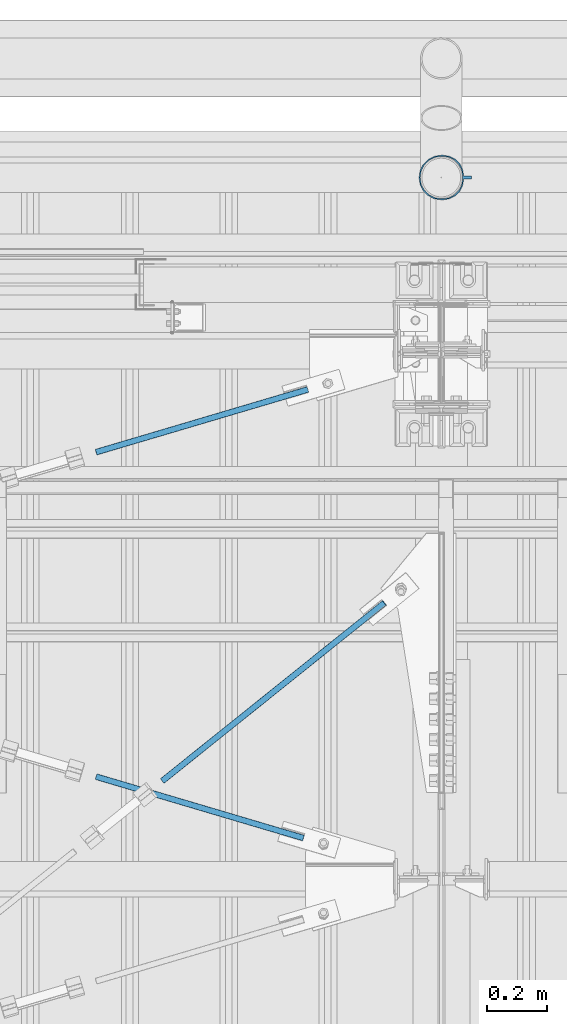
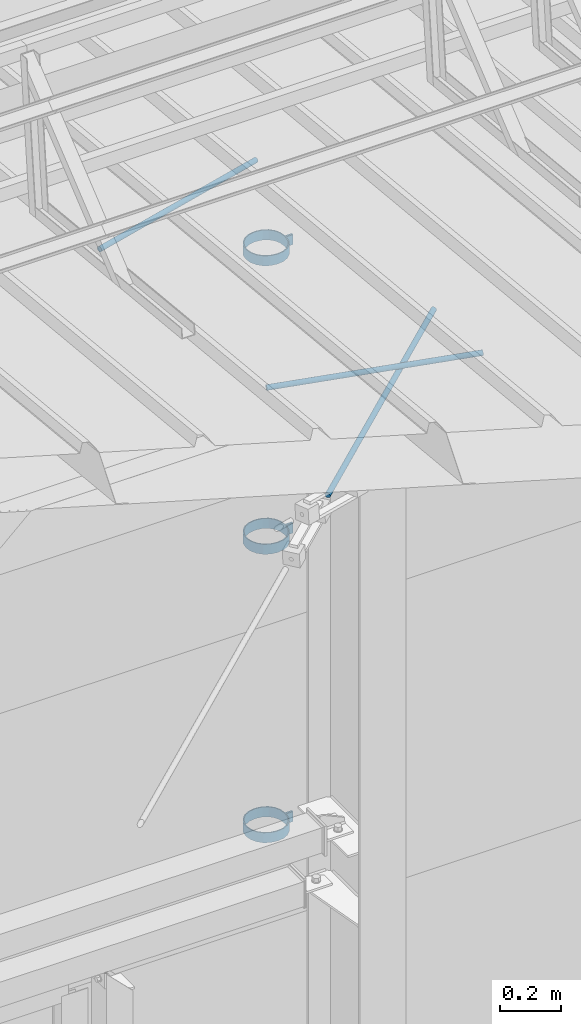
# One storey, part 322 of 709: 6 beams, 3 openings, 6 elements without a shape of their own.
"""IFC4 building model written with IfcOpenShell, lengths in millimetres."""

from ifc_helpers import new_model, si_unit, direction, frame, origin_with_axes, place, context, subcontext, project, spatial, line, indexed_curve, outline, extrude, polygons, material, element, aggregate, save


model = new_model("IFC4")

# Units and contexts
model_context = context("Model", 3, precision=0.2, world=origin_with_axes(), true_north=direction((0.0, 1.0)))
body_context = subcontext(model_context, "Body", "Model", "MODEL_VIEW")
reference_context = subcontext(model_context, "Reference", "Model", "MODEL_VIEW")
ifc_project = project(units=[si_unit("LENGTHUNIT", "METRE", prefix="MILLI"), si_unit("AREAUNIT", "SQUARE_METRE"), si_unit("VOLUMEUNIT", "CUBIC_METRE"), si_unit("MASSUNIT", "GRAM", prefix="KILO"), si_unit("TIMEUNIT", "SECOND"), si_unit("PLANEANGLEUNIT", "RADIAN"), si_unit("SOLIDANGLEUNIT", "STERADIAN"), si_unit("THERMODYNAMICTEMPERATUREUNIT", "DEGREE_CELSIUS"), si_unit("LUMINOUSINTENSITYUNIT", "LUMEN")], contexts=[model_context])

# Site, building, storey
site_placement = place(None, origin_with_axes())
site = spatial("IfcSite", under=ifc_project, at=site_placement, CompositionType="ELEMENT")
building_placement = place(site_placement, origin_with_axes())
building = spatial("IfcBuilding", under=site, at=building_placement, Name="Undefined", CompositionType="ELEMENT")
storey_placement = place(building_placement, origin_with_axes())
storey = spatial("IfcBuildingStorey", under=building, at=storey_placement, Name="Undefined", CompositionType="ELEMENT", Elevation=0.0)

# Assembly, beam, voiding feature
assembly_1_placement = place(storey_placement, frame((44916.07962, 20275.59044, 6772.92001), z_axis=(0.625451877, -0.7802627439, 1e-10), x_axis=(0.7742288439, 0.6206151549, 0.124123031)))
assembly_1 = element("IfcElementAssembly", 1, at=assembly_1_placement, inside=storey)
ifc_material_1 = material(Name="C355-5", Category="STEEL")
beam_1_placement = place(assembly_1_placement, origin_with_axes())
beam_1 = element("IfcBeam", 2, at=beam_1_placement, material=ifc_material_1, ObjectType="481", context=body_context, shape_type="Tessellation", body=[
    polygons([(1153.34134, -5.0, 8.66025), (1153.34134, -7.07107, 7.07107), (1153.34134, -8.66025, 5.0), (1153.34134, -9.65926, 2.58819), (1153.34134, -10.0, 0.0), (1153.34134, -9.65926, -2.58819), (1153.34134, -8.66025, -5.0), (1153.34134, -7.07107, -7.07107), (1153.34134, -5.0, -8.66025), (1153.34134, -2.58819, -9.65926), (1153.34134, 0.0, -10.0), (1153.34134, 2.58819, -9.65926), (1153.34134, 5.0, -8.66025), (1153.34134, 7.07107, -7.07107), (1153.34134, 8.66025, -5.0), (1153.34134, 9.65926, -2.58819), (1153.34134, 10.0, 0.0), (1153.34134, 9.65926, 2.58819), (1153.34134, 8.66025, 5.0), (1153.34134, 7.07107, 7.07107), (1153.34134, 5.0, 8.66025), (1153.34134, 2.58819, 9.65926), (1153.34134, 0.0, 10.0), (1153.34134, -2.58819, 9.65926), (190.0, 10.0, 0.0), (190.0, 9.65926, 2.58819), (190.0, 8.66025, 5.0), (190.0, 7.07107, 7.07107), (190.0, 5.0, 8.66025), (190.0, 2.58819, 9.65926), (190.0, 0.0, 10.0), (190.0, -2.58819, 9.65926), (190.0, -5.0, 8.66025), (190.0, -7.07107, 7.07107), (190.0, -8.66025, 5.0), (190.0, -9.65926, 2.58819), (190.0, -10.0, 0.0), (190.0, -9.65926, -2.58819), (190.0, -8.66025, -5.0), (190.0, -7.07107, -7.07107), (190.0, -5.0, -8.66025), (190.0, -2.58819, -9.65926), (190.0, 0.0, -10.0), (190.0, 2.58819, -9.65926), (190.0, 5.0, -8.66025), (190.0, 7.07107, -7.07107), (190.0, 8.66025, -5.0), (190.0, 9.65926, -2.58819), (10.0, 7.36122, 4.25), (190.0, 7.36122, 4.25), (190.0, 8.21037, 2.19996), (10.0, 8.21037, 2.19996), (10.0, 6.01041, 6.01041), (190.0, 6.01041, 6.01041), (10.0, 4.25, 7.36122), (190.0, 4.25, 7.36122), (10.0, 2.19996, 8.21037), (190.0, 2.19996, 8.21037), (10.0, 0.0, 8.5), (190.0, 0.0, 8.5), (10.0, -2.19996, 8.21037), (190.0, -2.19996, 8.21037), (10.0, -4.25, 7.36122), (190.0, -4.25, 7.36122), (10.0, -6.01041, 6.01041), (190.0, -6.01041, 6.01041), (10.0, -7.36122, 4.25), (190.0, -7.36122, 4.25), (10.0, -8.21037, 2.19996), (190.0, -8.21037, 2.19996), (10.0, -8.5, 0.0), (190.0, -8.5, 0.0), (10.0, -8.21037, -2.19996), (190.0, -8.21037, -2.19996), (10.0, -7.36122, -4.25), (190.0, -7.36122, -4.25), (10.0, -6.01041, -6.01041), (190.0, -6.01041, -6.01041), (10.0, -4.25, -7.36122), (190.0, -4.25, -7.36122), (10.0, -2.19996, -8.21037), (190.0, -2.19996, -8.21037), (10.0, 0.0, -8.5), (190.0, 0.0, -8.5), (10.0, 2.19996, -8.21037), (190.0, 2.19996, -8.21037), (10.0, 4.25, -7.36122), (190.0, 4.25, -7.36122), (10.0, 6.01041, -6.01041), (190.0, 6.01041, -6.01041), (10.0, 7.36122, -4.25), (190.0, 7.36122, -4.25), (10.0, 8.21037, -2.19996), (190.0, 8.21037, -2.19996), (10.0, 8.5, 0.0), (190.0, 8.5, 0.0)], [[[1, 2, 3, 4, 5, 6, 7, 8, 9, 10, 11, 12, 13, 14, 15, 16, 17, 18, 19, 20, 21, 22, 23, 24]], [[18, 17, 25, 26]], [[19, 18, 26, 27]], [[20, 19, 27, 28]], [[21, 20, 28, 29]], [[22, 21, 29, 30]], [[23, 22, 30, 31]], [[24, 23, 31, 32]], [[1, 24, 32, 33]], [[2, 1, 33, 34]], [[3, 2, 34, 35]], [[4, 3, 35, 36]], [[5, 4, 36, 37]], [[6, 5, 37, 38]], [[7, 6, 38, 39]], [[8, 7, 39, 40]], [[9, 8, 40, 41]], [[10, 9, 41, 42]], [[11, 10, 42, 43]], [[12, 11, 43, 44]], [[13, 12, 44, 45]], [[14, 13, 45, 46]], [[15, 14, 46, 47]], [[16, 15, 47, 48]], [[17, 16, 48, 25]], [[25, 48, 47, 46, 45, 44, 43, 42, 41, 40, 39, 38, 37, 36, 35, 34, 33, 32, 31, 30, 29, 28, 27, 26], [74, 76, 78, 80, 82, 84, 86, 88, 90, 92, 94, 96, 51, 50, 54, 56, 58, 60, 62, 64, 66, 68, 70, 72]], [[49, 50, 51, 52]], [[53, 54, 50, 49]], [[55, 56, 54, 53]], [[57, 58, 56, 55]], [[59, 60, 58, 57]], [[61, 62, 60, 59]], [[63, 64, 62, 61]], [[65, 66, 64, 63]], [[67, 68, 66, 65]], [[69, 70, 68, 67]], [[71, 72, 70, 69]], [[73, 74, 72, 71]], [[75, 76, 74, 73]], [[77, 78, 76, 75]], [[79, 80, 78, 77]], [[81, 82, 80, 79]], [[83, 84, 82, 81]], [[85, 86, 84, 83]], [[87, 88, 86, 85]], [[89, 90, 88, 87]], [[91, 92, 90, 89]], [[93, 94, 92, 91]], [[95, 96, 94, 93]], [[52, 51, 96, 95]], [[91, 89, 87, 85, 83, 81, 79, 77, 75, 73, 71, 69, 67, 65, 63, 61, 59, 57, 55, 53, 49, 52, 95, 93]]], closed=True),
])
voiding_feature_1_placement = place(beam_1_placement, frame((10.0, 0.0, 0.0), z_axis=(0.0, -1.0, 0.0), x_axis=(1.0, 0.0, 0.0)))
element("IfcVoidingFeature", 3, at=voiding_feature_1_placement, cuts=beam_1, PredefinedType="HOLE", context=reference_context, identifier="Reference", shape_type="SolidModel", body=[
    extrude(outline(indexed_curve([(10.5, 0.0), (10.14222, 2.7176), (9.09327, 5.25), (7.42462, 7.42462), (5.25, 9.09327), (2.7176, 10.14222), (0.0, 10.5), (-2.7176, 10.14222), (-5.25, 9.09327), (-7.42462, 7.42462), (-9.09327, 5.25), (-10.14222, 2.7176), (-10.5, 0.0), (-10.14222, -2.7176), (-9.09327, -5.25), (-7.42462, -7.42462), (-5.25, -9.09327), (-2.7176, -10.14222), (0.0, -10.5), (2.7176, -10.14222), (5.25, -9.09327), (7.42462, -7.42462), (9.09327, -5.25), (10.14222, -2.7176)], segments=[line(1, 2, 3, 4, 5, 6, 7, 8, 9, 10, 11, 12, 13, 14, 15, 16, 17, 18, 19, 20, 21, 22, 23, 24, 1)])), frame((0.0, 0.0, 0.0), z_axis=(-1.0, 0.0, 0.0), x_axis=(0.0, 0.0, 1.0)), (0.0, 0.0, -1.0), 180.0),
])
aggregate(assembly_1, [beam_1])

assembly_2_placement = place(storey_placement, frame((44658.15773, 21443.50385, 7192.15363), z_axis=(0.2852311229, -0.9537021177, 0.0953702118), x_axis=(0.9584587662, 0.2838155751, -0.028381558)))
assembly_2 = element("IfcElementAssembly", 4, at=assembly_2_placement, inside=storey)
beam_2_placement = place(assembly_2_placement, origin_with_axes())
beam_2 = element("IfcBeam", 5, at=beam_2_placement, material=ifc_material_1, ObjectType="571", context=body_context, shape_type="Tessellation", body=[
    polygons([(931.9749, -5.0, 8.66025), (931.9749, -7.07107, 7.07107), (931.9749, -8.66025, 5.0), (931.9749, -9.65926, 2.58819), (931.9749, -10.0, 0.0), (931.9749, -9.65926, -2.58819), (931.9749, -8.66025, -5.0), (931.9749, -7.07107, -7.07107), (931.9749, -5.0, -8.66025), (931.9749, -2.58819, -9.65926), (931.9749, 0.0, -10.0), (931.9749, 2.58819, -9.65926), (931.9749, 5.0, -8.66025), (931.9749, 7.07107, -7.07107), (931.9749, 8.66025, -5.0), (931.9749, 9.65926, -2.58819), (931.9749, 10.0, 0.0), (931.9749, 9.65926, 2.58819), (931.9749, 8.66025, 5.0), (931.9749, 7.07107, 7.07107), (931.9749, 5.0, 8.66025), (931.9749, 2.58819, 9.65926), (931.9749, 0.0, 10.0), (931.9749, -2.58819, 9.65926), (190.0, 10.0, 0.0), (190.0, 9.65926, 2.58819), (190.0, 8.66025, 5.0), (190.0, 7.07107, 7.07107), (190.0, 5.0, 8.66025), (190.0, 2.58819, 9.65926), (190.0, 0.0, 10.0), (190.0, -2.58819, 9.65926), (190.0, -5.0, 8.66025), (190.0, -7.07107, 7.07107), (190.0, -8.66025, 5.0), (190.0, -9.65926, 2.58819), (190.0, -10.0, 0.0), (190.0, -9.65926, -2.58819), (190.0, -8.66025, -5.0), (190.0, -7.07107, -7.07107), (190.0, -5.0, -8.66025), (190.0, -2.58819, -9.65926), (190.0, 0.0, -10.0), (190.0, 2.58819, -9.65926), (190.0, 5.0, -8.66025), (190.0, 7.07107, -7.07107), (190.0, 8.66025, -5.0), (190.0, 9.65926, -2.58819), (10.0, 7.36122, 4.25), (190.0, 7.36122, 4.25), (190.0, 8.21037, 2.19996), (10.0, 8.21037, 2.19996), (10.0, 6.01041, 6.01041), (190.0, 6.01041, 6.01041), (10.0, 4.25, 7.36122), (190.0, 4.25, 7.36122), (10.0, 2.19996, 8.21037), (190.0, 2.19996, 8.21037), (10.0, 0.0, 8.5), (190.0, 0.0, 8.5), (10.0, -2.19996, 8.21037), (190.0, -2.19996, 8.21037), (10.0, -4.25, 7.36122), (190.0, -4.25, 7.36122), (10.0, -6.01041, 6.01041), (190.0, -6.01041, 6.01041), (10.0, -7.36122, 4.25), (190.0, -7.36122, 4.25), (10.0, -8.21037, 2.19996), (190.0, -8.21037, 2.19996), (10.0, -8.5, 0.0), (190.0, -8.5, 0.0), (10.0, -8.21037, -2.19996), (190.0, -8.21037, -2.19996), (10.0, -7.36122, -4.25), (190.0, -7.36122, -4.25), (10.0, -6.01041, -6.01041), (190.0, -6.01041, -6.01041), (10.0, -4.25, -7.36122), (190.0, -4.25, -7.36122), (10.0, -2.19996, -8.21037), (190.0, -2.19996, -8.21037), (10.0, 0.0, -8.5), (190.0, 0.0, -8.5), (10.0, 2.19996, -8.21037), (190.0, 2.19996, -8.21037), (10.0, 4.25, -7.36122), (190.0, 4.25, -7.36122), (10.0, 6.01041, -6.01041), (190.0, 6.01041, -6.01041), (10.0, 7.36122, -4.25), (190.0, 7.36122, -4.25), (10.0, 8.21037, -2.19996), (190.0, 8.21037, -2.19996), (10.0, 8.5, 0.0), (190.0, 8.5, 0.0)], [[[1, 2, 3, 4, 5, 6, 7, 8, 9, 10, 11, 12, 13, 14, 15, 16, 17, 18, 19, 20, 21, 22, 23, 24]], [[18, 17, 25, 26]], [[19, 18, 26, 27]], [[20, 19, 27, 28]], [[21, 20, 28, 29]], [[22, 21, 29, 30]], [[23, 22, 30, 31]], [[24, 23, 31, 32]], [[1, 24, 32, 33]], [[2, 1, 33, 34]], [[3, 2, 34, 35]], [[4, 3, 35, 36]], [[5, 4, 36, 37]], [[6, 5, 37, 38]], [[7, 6, 38, 39]], [[8, 7, 39, 40]], [[9, 8, 40, 41]], [[10, 9, 41, 42]], [[11, 10, 42, 43]], [[12, 11, 43, 44]], [[13, 12, 44, 45]], [[14, 13, 45, 46]], [[15, 14, 46, 47]], [[16, 15, 47, 48]], [[17, 16, 48, 25]], [[25, 48, 47, 46, 45, 44, 43, 42, 41, 40, 39, 38, 37, 36, 35, 34, 33, 32, 31, 30, 29, 28, 27, 26], [74, 76, 78, 80, 82, 84, 86, 88, 90, 92, 94, 96, 51, 50, 54, 56, 58, 60, 62, 64, 66, 68, 70, 72]], [[49, 50, 51, 52]], [[53, 54, 50, 49]], [[55, 56, 54, 53]], [[57, 58, 56, 55]], [[59, 60, 58, 57]], [[61, 62, 60, 59]], [[63, 64, 62, 61]], [[65, 66, 64, 63]], [[67, 68, 66, 65]], [[69, 70, 68, 67]], [[71, 72, 70, 69]], [[73, 74, 72, 71]], [[75, 76, 74, 73]], [[77, 78, 76, 75]], [[79, 80, 78, 77]], [[81, 82, 80, 79]], [[83, 84, 82, 81]], [[85, 86, 84, 83]], [[87, 88, 86, 85]], [[89, 90, 88, 87]], [[91, 92, 90, 89]], [[93, 94, 92, 91]], [[95, 96, 94, 93]], [[52, 51, 96, 95]], [[91, 89, 87, 85, 83, 81, 79, 77, 75, 73, 71, 69, 67, 65, 63, 61, 59, 57, 55, 53, 49, 52, 95, 93]]], closed=True),
])
voiding_feature_2_placement = place(beam_2_placement, frame((10.0, 0.0, 0.0), z_axis=(0.0, -1.0, 0.0), x_axis=(1.0, 0.0, 0.0)))
element("IfcVoidingFeature", 6, at=voiding_feature_2_placement, cuts=beam_2, PredefinedType="HOLE", context=reference_context, identifier="Reference", shape_type="SolidModel", body=[
    extrude(outline(indexed_curve([(10.5, 0.0), (10.14222, 2.7176), (9.09327, 5.25), (7.42462, 7.42462), (5.25, 9.09327), (2.7176, 10.14222), (0.0, 10.5), (-2.7176, 10.14222), (-5.25, 9.09327), (-7.42462, 7.42462), (-9.09327, 5.25), (-10.14222, 2.7176), (-10.5, 0.0), (-10.14222, -2.7176), (-9.09327, -5.25), (-7.42462, -7.42462), (-5.25, -9.09327), (-2.7176, -10.14222), (0.0, -10.5), (2.7176, -10.14222), (5.25, -9.09327), (7.42462, -7.42462), (9.09327, -5.25), (10.14222, -2.7176)], segments=[line(1, 2, 3, 4, 5, 6, 7, 8, 9, 10, 11, 12, 13, 14, 15, 16, 17, 18, 19, 20, 21, 22, 23, 24, 1)])), frame((0.0, 0.0, 0.0), z_axis=(-1.0, 0.0, 0.0), x_axis=(0.0, 0.0, 1.0)), (0.0, 0.0, -1.0), 180.0),
])
aggregate(assembly_2, [beam_2])

assembly_3_placement = place(storey_placement, frame((44658.15773, 20461.48771, 7290.35524), z_axis=(-0.2852311229, -0.9537021177, 0.0953702118), x_axis=(0.9584587662, -0.2838155751, 0.028381558)))
assembly_3 = element("IfcElementAssembly", 7, at=assembly_3_placement, inside=storey)
beam_3_placement = place(assembly_3_placement, origin_with_axes())
beam_3 = element("IfcBeam", 8, at=beam_3_placement, material=ifc_material_1, ObjectType="569", context=body_context, shape_type="Tessellation", body=[
    polygons([(916.9749, -5.0, 8.66025), (916.9749, -7.07107, 7.07107), (916.9749, -8.66025, 5.0), (916.9749, -9.65926, 2.58819), (916.9749, -10.0, 0.0), (916.9749, -9.65926, -2.58819), (916.9749, -8.66025, -5.0), (916.9749, -7.07107, -7.07107), (916.9749, -5.0, -8.66025), (916.9749, -2.58819, -9.65926), (916.9749, 0.0, -10.0), (916.9749, 2.58819, -9.65926), (916.9749, 5.0, -8.66025), (916.9749, 7.07107, -7.07107), (916.9749, 8.66025, -5.0), (916.9749, 9.65926, -2.58819), (916.9749, 10.0, 0.0), (916.9749, 9.65926, 2.58819), (916.9749, 8.66025, 5.0), (916.9749, 7.07107, 7.07107), (916.9749, 5.0, 8.66025), (916.9749, 2.58819, 9.65926), (916.9749, 0.0, 10.0), (916.9749, -2.58819, 9.65926), (190.0, 10.0, 0.0), (190.0, 9.65926, 2.58819), (190.0, 8.66025, 5.0), (190.0, 7.07107, 7.07107), (190.0, 5.0, 8.66025), (190.0, 2.58819, 9.65926), (190.0, 0.0, 10.0), (190.0, -2.58819, 9.65926), (190.0, -5.0, 8.66025), (190.0, -7.07107, 7.07107), (190.0, -8.66025, 5.0), (190.0, -9.65926, 2.58819), (190.0, -10.0, 0.0), (190.0, -9.65926, -2.58819), (190.0, -8.66025, -5.0), (190.0, -7.07107, -7.07107), (190.0, -5.0, -8.66025), (190.0, -2.58819, -9.65926), (190.0, 0.0, -10.0), (190.0, 2.58819, -9.65926), (190.0, 5.0, -8.66025), (190.0, 7.07107, -7.07107), (190.0, 8.66025, -5.0), (190.0, 9.65926, -2.58819), (10.0, 7.36122, 4.25), (190.0, 7.36122, 4.25), (190.0, 8.21037, 2.19996), (10.0, 8.21037, 2.19996), (10.0, 6.01041, 6.01041), (190.0, 6.01041, 6.01041), (10.0, 4.25, 7.36122), (190.0, 4.25, 7.36122), (10.0, 2.19996, 8.21037), (190.0, 2.19996, 8.21037), (10.0, 0.0, 8.5), (190.0, 0.0, 8.5), (10.0, -2.19996, 8.21037), (190.0, -2.19996, 8.21037), (10.0, -4.25, 7.36122), (190.0, -4.25, 7.36122), (10.0, -6.01041, 6.01041), (190.0, -6.01041, 6.01041), (10.0, -7.36122, 4.25), (190.0, -7.36122, 4.25), (10.0, -8.21037, 2.19996), (190.0, -8.21037, 2.19996), (10.0, -8.5, 0.0), (190.0, -8.5, 0.0), (10.0, -8.21037, -2.19996), (190.0, -8.21037, -2.19996), (10.0, -7.36122, -4.25), (190.0, -7.36122, -4.25), (10.0, -6.01041, -6.01041), (190.0, -6.01041, -6.01041), (10.0, -4.25, -7.36122), (190.0, -4.25, -7.36122), (10.0, -2.19996, -8.21037), (190.0, -2.19996, -8.21037), (10.0, 0.0, -8.5), (190.0, 0.0, -8.5), (10.0, 2.19996, -8.21037), (190.0, 2.19996, -8.21037), (10.0, 4.25, -7.36122), (190.0, 4.25, -7.36122), (10.0, 6.01041, -6.01041), (190.0, 6.01041, -6.01041), (10.0, 7.36122, -4.25), (190.0, 7.36122, -4.25), (10.0, 8.21037, -2.19996), (190.0, 8.21037, -2.19996), (10.0, 8.5, 0.0), (190.0, 8.5, 0.0)], [[[1, 2, 3, 4, 5, 6, 7, 8, 9, 10, 11, 12, 13, 14, 15, 16, 17, 18, 19, 20, 21, 22, 23, 24]], [[18, 17, 25, 26]], [[19, 18, 26, 27]], [[20, 19, 27, 28]], [[21, 20, 28, 29]], [[22, 21, 29, 30]], [[23, 22, 30, 31]], [[24, 23, 31, 32]], [[1, 24, 32, 33]], [[2, 1, 33, 34]], [[3, 2, 34, 35]], [[4, 3, 35, 36]], [[5, 4, 36, 37]], [[6, 5, 37, 38]], [[7, 6, 38, 39]], [[8, 7, 39, 40]], [[9, 8, 40, 41]], [[10, 9, 41, 42]], [[11, 10, 42, 43]], [[12, 11, 43, 44]], [[13, 12, 44, 45]], [[14, 13, 45, 46]], [[15, 14, 46, 47]], [[16, 15, 47, 48]], [[17, 16, 48, 25]], [[25, 48, 47, 46, 45, 44, 43, 42, 41, 40, 39, 38, 37, 36, 35, 34, 33, 32, 31, 30, 29, 28, 27, 26], [74, 76, 78, 80, 82, 84, 86, 88, 90, 92, 94, 96, 51, 50, 54, 56, 58, 60, 62, 64, 66, 68, 70, 72]], [[49, 50, 51, 52]], [[53, 54, 50, 49]], [[55, 56, 54, 53]], [[57, 58, 56, 55]], [[59, 60, 58, 57]], [[61, 62, 60, 59]], [[63, 64, 62, 61]], [[65, 66, 64, 63]], [[67, 68, 66, 65]], [[69, 70, 68, 67]], [[71, 72, 70, 69]], [[73, 74, 72, 71]], [[75, 76, 74, 73]], [[77, 78, 76, 75]], [[79, 80, 78, 77]], [[81, 82, 80, 79]], [[83, 84, 82, 81]], [[85, 86, 84, 83]], [[87, 88, 86, 85]], [[89, 90, 88, 87]], [[91, 92, 90, 89]], [[93, 94, 92, 91]], [[95, 96, 94, 93]], [[52, 51, 96, 95]], [[91, 89, 87, 85, 83, 81, 79, 77, 75, 73, 71, 69, 67, 65, 63, 61, 59, 57, 55, 53, 49, 52, 95, 93]]], closed=True),
])
voiding_feature_3_placement = place(beam_3_placement, frame((10.0, 0.0, 0.0), z_axis=(0.0, -1.0, 0.0), x_axis=(1.0, 0.0, 0.0)))
element("IfcVoidingFeature", 9, at=voiding_feature_3_placement, cuts=beam_3, PredefinedType="HOLE", context=reference_context, identifier="Reference", shape_type="SolidModel", body=[
    extrude(outline(indexed_curve([(10.5, 0.0), (10.14222, 2.7176), (9.09327, 5.25), (7.42462, 7.42462), (5.25, 9.09327), (2.7176, 10.14222), (0.0, 10.5), (-2.7176, 10.14222), (-5.25, 9.09327), (-7.42462, 7.42462), (-9.09327, 5.25), (-10.14222, 2.7176), (-10.5, 0.0), (-10.14222, -2.7176), (-9.09327, -5.25), (-7.42462, -7.42462), (-5.25, -9.09327), (-2.7176, -10.14222), (0.0, -10.5), (2.7176, -10.14222), (5.25, -9.09327), (7.42462, -7.42462), (9.09327, -5.25), (10.14222, -2.7176)], segments=[line(1, 2, 3, 4, 5, 6, 7, 8, 9, 10, 11, 12, 13, 14, 15, 16, 17, 18, 19, 20, 21, 22, 23, 24, 1)])), frame((0.0, 0.0, 0.0), z_axis=(-1.0, 0.0, 0.0), x_axis=(0.0, 0.0, 1.0)), (0.0, 0.0, -1.0), 180.0),
])
aggregate(assembly_3, [beam_3])

# Assembly, beam
assembly_4_placement = place(storey_placement, frame((46101.0, 22422.5, 6226.92297), z_axis=(0.0, 1.0, 0.0), x_axis=(-1.0, 0.0, 0.0)))
assembly_4 = element("IfcElementAssembly", 10, at=assembly_4_placement, inside=storey)
ifc_material_2 = material(Name="Steel_Undefined", Category="STEEL")
beam_4_placement = place(assembly_4_placement, origin_with_axes())
beam_4 = element("IfcBeam", 11, at=beam_4_placement, material=ifc_material_2, ObjectType="616", context=body_context, shape_type="Tessellation", body=[
    polygons([(0.0, -20.0, 2.0), (0.0, 20.0, 2.0), (0.0, 20.0, -2.0), (0.0, -20.0, -2.0), (30.0, 20.0, -2.0), (30.0, -20.0, -2.0), (26.0, -20.0, 2.0), (26.0, 20.0, 2.0), (30.0, 20.0, 3.5), (30.0, -20.0, 3.5), (26.0, -20.0, 3.5), (26.0, 20.0, 3.5), (33.18133, 20.0, 23.5861), (33.18133, -20.0, 23.5861), (29.3771, -20.0, 24.82217), (29.3771, 20.0, 24.82217), (39.17783, -20.0, 44.05718), (39.17783, 20.0, 44.05718), (42.4139, 20.0, 41.70604), (42.4139, -20.0, 41.70604), (54.44282, -20.0, 59.32217), (54.44282, 20.0, 59.32217), (56.79396, 20.0, 56.0861), (56.79396, -20.0, 56.0861), (73.67783, -20.0, 69.1229), (73.67783, 20.0, 69.1229), (74.9139, 20.0, 65.31867), (74.9139, -20.0, 65.31867), (95.0, -20.0, 72.5), (95.0, 20.0, 72.5), (95.0, 20.0, 68.5), (95.0, -20.0, 68.5), (102.0, 20.0, 68.5), (102.0, -20.0, 68.5), (102.0, -20.0, 72.5), (102.0, 20.0, 72.5), (123.63119, 20.0, 65.07396), (123.63119, -20.0, 65.07396), (124.86726, -20.0, 68.87818), (124.86726, 20.0, 68.87818), (145.49611, -20.0, 58.36726), (145.49611, 20.0, 58.36726), (143.14497, 20.0, 55.13119), (143.14497, -20.0, 55.13119), (161.86726, -20.0, 41.99611), (161.86726, 20.0, 41.99611), (158.63119, 20.0, 39.64497), (158.63119, -20.0, 39.64497), (172.37818, -20.0, 21.36726), (172.37818, 20.0, 21.36726), (168.57396, 20.0, 20.13119), (168.57396, -20.0, 20.13119), (176.0, -20.0, -1.5), (176.0, 20.0, -1.5), (172.0, 20.0, -1.5), (172.0, -20.0, -1.5), (172.0, 20.0, -3.5), (172.0, -20.0, -3.5), (176.0, -20.0, -3.5), (176.0, 20.0, -3.5), (168.57396, 20.0, -25.13119), (168.57396, -20.0, -25.13119), (172.37818, -20.0, -26.36726), (172.37818, 20.0, -26.36726), (161.86726, -20.0, -46.99611), (161.86726, 20.0, -46.99611), (158.63119, 20.0, -44.64497), (158.63119, -20.0, -44.64497), (145.49611, -20.0, -63.36726), (145.49611, 20.0, -63.36726), (143.14497, 20.0, -60.13119), (143.14497, -20.0, -60.13119), (124.86726, -20.0, -73.87818), (124.86726, 20.0, -73.87818), (123.63119, 20.0, -70.07396), (123.63119, -20.0, -70.07396), (102.0, -20.0, -77.5), (102.0, 20.0, -77.5), (102.0, 20.0, -73.5), (102.0, -20.0, -73.5), (95.0, 20.0, -73.5), (95.0, -20.0, -73.5), (95.0, -20.0, -77.5), (95.0, 20.0, -77.5), (74.9139, 20.0, -70.31867), (74.9139, -20.0, -70.31867), (73.67783, -20.0, -74.1229), (73.67783, 20.0, -74.1229), (54.44282, -20.0, -64.32217), (54.44282, 20.0, -64.32217), (56.79396, 20.0, -61.0861), (56.79396, -20.0, -61.0861), (39.17783, -20.0, -49.05718), (39.17783, 20.0, -49.05718), (42.4139, 20.0, -46.70604), (42.4139, -20.0, -46.70604), (29.3771, -20.0, -29.82217), (29.3771, 20.0, -29.82217), (33.18133, 20.0, -28.5861), (33.18133, -20.0, -28.5861), (26.0, -20.0, -8.5), (26.0, 20.0, -8.5), (30.0, 20.0, -8.5), (30.0, -20.0, -8.5), (30.0, 20.0, -3.0), (30.0, -20.0, -3.0), (26.0, -20.0, -7.0), (26.0, 20.0, -7.0), (0.0, 20.0, -3.0), (0.0, -20.0, -3.0), (0.0, 20.0, -7.0), (0.0, -20.0, -7.0)], [[[1, 2, 3, 4]], [[4, 3, 5, 6]], [[2, 1, 7, 8]], [[6, 5, 9, 10]], [[8, 7, 11, 12]], [[10, 9, 13, 14]], [[12, 11, 15, 16]], [[15, 17, 18, 16]], [[13, 19, 20, 14]], [[17, 21, 22, 18]], [[19, 23, 24, 20]], [[21, 25, 26, 22]], [[23, 27, 28, 24]], [[25, 29, 30, 26]], [[27, 31, 32, 28]], [[32, 31, 33, 34]], [[30, 29, 35, 36]], [[34, 33, 37, 38]], [[36, 35, 39, 40]], [[39, 41, 42, 40]], [[37, 43, 44, 38]], [[41, 45, 46, 42]], [[43, 47, 48, 44]], [[45, 49, 50, 46]], [[47, 51, 52, 48]], [[49, 53, 54, 50]], [[51, 55, 56, 52]], [[56, 55, 57, 58]], [[54, 53, 59, 60]], [[58, 57, 61, 62]], [[60, 59, 63, 64]], [[63, 65, 66, 64]], [[61, 67, 68, 62]], [[65, 69, 70, 66]], [[67, 71, 72, 68]], [[69, 73, 74, 70]], [[71, 75, 76, 72]], [[73, 77, 78, 74]], [[75, 79, 80, 76]], [[80, 79, 81, 82]], [[78, 77, 83, 84]], [[82, 81, 85, 86]], [[84, 83, 87, 88]], [[87, 89, 90, 88]], [[85, 91, 92, 86]], [[89, 93, 94, 90]], [[91, 95, 96, 92]], [[93, 97, 98, 94]], [[95, 99, 100, 96]], [[97, 101, 102, 98]], [[99, 103, 104, 100]], [[104, 103, 105, 106]], [[102, 101, 107, 108]], [[106, 105, 109, 110]], [[105, 103, 99, 95, 91, 85, 81, 79, 75, 71, 67, 61, 57, 55, 51, 47, 43, 37, 33, 31, 27, 23, 19, 13, 9, 5, 3, 2, 8, 12, 16, 18, 22, 26, 30, 36, 40, 42, 46, 50, 54, 60, 64, 66, 70, 74, 78, 84, 88, 90, 94, 98, 102, 108, 111, 109]], [[108, 107, 112, 111]], [[107, 101, 97, 93, 89, 87, 83, 77, 73, 69, 65, 63, 59, 53, 49, 45, 41, 39, 35, 29, 25, 21, 17, 15, 11, 7, 1, 4, 6, 10, 14, 20, 24, 28, 32, 34, 38, 44, 48, 52, 56, 58, 62, 68, 72, 76, 80, 82, 86, 92, 96, 100, 104, 106, 110, 112]], [[111, 112, 110, 109]]], closed=True),
])
aggregate(assembly_4, [beam_4])

assembly_5_placement = place(storey_placement, frame((46101.0, 22422.5, 5076.92297), z_axis=(0.0, 1.0, 0.0), x_axis=(-1.0, 0.0, 0.0)))
assembly_5 = element("IfcElementAssembly", 12, at=assembly_5_placement, inside=storey)
beam_5_placement = place(assembly_5_placement, origin_with_axes())
beam_5 = element("IfcBeam", 13, at=beam_5_placement, material=ifc_material_2, ObjectType="616", context=body_context, shape_type="Tessellation", body=[
    polygons([(0.0, -20.0, 2.0), (0.0, 20.0, 2.0), (0.0, 20.0, -2.0), (0.0, -20.0, -2.0), (30.0, 20.0, -2.0), (30.0, -20.0, -2.0), (26.0, -20.0, 2.0), (26.0, 20.0, 2.0), (30.0, 20.0, 3.5), (30.0, -20.0, 3.5), (26.0, -20.0, 3.5), (26.0, 20.0, 3.5), (33.18133, 20.0, 23.5861), (33.18133, -20.0, 23.5861), (29.3771, -20.0, 24.82217), (29.3771, 20.0, 24.82217), (39.17783, -20.0, 44.05718), (39.17783, 20.0, 44.05718), (42.4139, 20.0, 41.70604), (42.4139, -20.0, 41.70604), (54.44282, -20.0, 59.32217), (54.44282, 20.0, 59.32217), (56.79396, 20.0, 56.0861), (56.79396, -20.0, 56.0861), (73.67783, -20.0, 69.1229), (73.67783, 20.0, 69.1229), (74.9139, 20.0, 65.31867), (74.9139, -20.0, 65.31867), (95.0, -20.0, 72.5), (95.0, 20.0, 72.5), (95.0, 20.0, 68.5), (95.0, -20.0, 68.5), (102.0, 20.0, 68.5), (102.0, -20.0, 68.5), (102.0, -20.0, 72.5), (102.0, 20.0, 72.5), (123.63119, 20.0, 65.07396), (123.63119, -20.0, 65.07396), (124.86726, -20.0, 68.87818), (124.86726, 20.0, 68.87818), (145.49611, -20.0, 58.36726), (145.49611, 20.0, 58.36726), (143.14497, 20.0, 55.13119), (143.14497, -20.0, 55.13119), (161.86726, -20.0, 41.99611), (161.86726, 20.0, 41.99611), (158.63119, 20.0, 39.64497), (158.63119, -20.0, 39.64497), (172.37818, -20.0, 21.36726), (172.37818, 20.0, 21.36726), (168.57396, 20.0, 20.13119), (168.57396, -20.0, 20.13119), (176.0, -20.0, -1.5), (176.0, 20.0, -1.5), (172.0, 20.0, -1.5), (172.0, -20.0, -1.5), (172.0, 20.0, -3.5), (172.0, -20.0, -3.5), (176.0, -20.0, -3.5), (176.0, 20.0, -3.5), (168.57396, 20.0, -25.13119), (168.57396, -20.0, -25.13119), (172.37818, -20.0, -26.36726), (172.37818, 20.0, -26.36726), (161.86726, -20.0, -46.99611), (161.86726, 20.0, -46.99611), (158.63119, 20.0, -44.64497), (158.63119, -20.0, -44.64497), (145.49611, -20.0, -63.36726), (145.49611, 20.0, -63.36726), (143.14497, 20.0, -60.13119), (143.14497, -20.0, -60.13119), (124.86726, -20.0, -73.87818), (124.86726, 20.0, -73.87818), (123.63119, 20.0, -70.07396), (123.63119, -20.0, -70.07396), (102.0, -20.0, -77.5), (102.0, 20.0, -77.5), (102.0, 20.0, -73.5), (102.0, -20.0, -73.5), (95.0, 20.0, -73.5), (95.0, -20.0, -73.5), (95.0, -20.0, -77.5), (95.0, 20.0, -77.5), (74.9139, 20.0, -70.31867), (74.9139, -20.0, -70.31867), (73.67783, -20.0, -74.1229), (73.67783, 20.0, -74.1229), (54.44282, -20.0, -64.32217), (54.44282, 20.0, -64.32217), (56.79396, 20.0, -61.0861), (56.79396, -20.0, -61.0861), (39.17783, -20.0, -49.05718), (39.17783, 20.0, -49.05718), (42.4139, 20.0, -46.70604), (42.4139, -20.0, -46.70604), (29.3771, -20.0, -29.82217), (29.3771, 20.0, -29.82217), (33.18133, 20.0, -28.5861), (33.18133, -20.0, -28.5861), (26.0, -20.0, -8.5), (26.0, 20.0, -8.5), (30.0, 20.0, -8.5), (30.0, -20.0, -8.5), (30.0, 20.0, -3.0), (30.0, -20.0, -3.0), (26.0, -20.0, -7.0), (26.0, 20.0, -7.0), (0.0, 20.0, -3.0), (0.0, -20.0, -3.0), (0.0, 20.0, -7.0), (0.0, -20.0, -7.0)], [[[1, 2, 3, 4]], [[4, 3, 5, 6]], [[2, 1, 7, 8]], [[6, 5, 9, 10]], [[8, 7, 11, 12]], [[10, 9, 13, 14]], [[12, 11, 15, 16]], [[15, 17, 18, 16]], [[13, 19, 20, 14]], [[17, 21, 22, 18]], [[19, 23, 24, 20]], [[21, 25, 26, 22]], [[23, 27, 28, 24]], [[25, 29, 30, 26]], [[27, 31, 32, 28]], [[32, 31, 33, 34]], [[30, 29, 35, 36]], [[34, 33, 37, 38]], [[36, 35, 39, 40]], [[39, 41, 42, 40]], [[37, 43, 44, 38]], [[41, 45, 46, 42]], [[43, 47, 48, 44]], [[45, 49, 50, 46]], [[47, 51, 52, 48]], [[49, 53, 54, 50]], [[51, 55, 56, 52]], [[56, 55, 57, 58]], [[54, 53, 59, 60]], [[58, 57, 61, 62]], [[60, 59, 63, 64]], [[63, 65, 66, 64]], [[61, 67, 68, 62]], [[65, 69, 70, 66]], [[67, 71, 72, 68]], [[69, 73, 74, 70]], [[71, 75, 76, 72]], [[73, 77, 78, 74]], [[75, 79, 80, 76]], [[80, 79, 81, 82]], [[78, 77, 83, 84]], [[82, 81, 85, 86]], [[84, 83, 87, 88]], [[87, 89, 90, 88]], [[85, 91, 92, 86]], [[89, 93, 94, 90]], [[91, 95, 96, 92]], [[93, 97, 98, 94]], [[95, 99, 100, 96]], [[97, 101, 102, 98]], [[99, 103, 104, 100]], [[104, 103, 105, 106]], [[102, 101, 107, 108]], [[106, 105, 109, 110]], [[105, 103, 99, 95, 91, 85, 81, 79, 75, 71, 67, 61, 57, 55, 51, 47, 43, 37, 33, 31, 27, 23, 19, 13, 9, 5, 3, 2, 8, 12, 16, 18, 22, 26, 30, 36, 40, 42, 46, 50, 54, 60, 64, 66, 70, 74, 78, 84, 88, 90, 94, 98, 102, 108, 111, 109]], [[108, 107, 112, 111]], [[107, 101, 97, 93, 89, 87, 83, 77, 73, 69, 65, 63, 59, 53, 49, 45, 41, 39, 35, 29, 25, 21, 17, 15, 11, 7, 1, 4, 6, 10, 14, 20, 24, 28, 32, 34, 38, 44, 48, 52, 56, 58, 62, 68, 72, 76, 80, 82, 86, 92, 96, 100, 104, 106, 110, 112]], [[111, 112, 110, 109]]], closed=True),
])
aggregate(assembly_5, [beam_5])

assembly_6_placement = place(storey_placement, frame((46101.0, 22422.5, 3926.92297), z_axis=(0.0, 1.0, 0.0), x_axis=(-1.0, 0.0, 0.0)))
assembly_6 = element("IfcElementAssembly", 14, at=assembly_6_placement, inside=storey)
beam_6_placement = place(assembly_6_placement, origin_with_axes())
beam_6 = element("IfcBeam", 15, at=beam_6_placement, material=ifc_material_2, ObjectType="616", context=body_context, shape_type="Tessellation", body=[
    polygons([(0.0, -20.0, 2.0), (0.0, 20.0, 2.0), (0.0, 20.0, -2.0), (0.0, -20.0, -2.0), (30.0, 20.0, -2.0), (30.0, -20.0, -2.0), (26.0, -20.0, 2.0), (26.0, 20.0, 2.0), (30.0, 20.0, 3.5), (30.0, -20.0, 3.5), (26.0, -20.0, 3.5), (26.0, 20.0, 3.5), (33.18133, 20.0, 23.5861), (33.18133, -20.0, 23.5861), (29.3771, -20.0, 24.82217), (29.3771, 20.0, 24.82217), (39.17783, -20.0, 44.05718), (39.17783, 20.0, 44.05718), (42.4139, 20.0, 41.70604), (42.4139, -20.0, 41.70604), (54.44282, -20.0, 59.32217), (54.44282, 20.0, 59.32217), (56.79396, 20.0, 56.0861), (56.79396, -20.0, 56.0861), (73.67783, -20.0, 69.1229), (73.67783, 20.0, 69.1229), (74.9139, 20.0, 65.31867), (74.9139, -20.0, 65.31867), (95.0, -20.0, 72.5), (95.0, 20.0, 72.5), (95.0, 20.0, 68.5), (95.0, -20.0, 68.5), (102.0, 20.0, 68.5), (102.0, -20.0, 68.5), (102.0, -20.0, 72.5), (102.0, 20.0, 72.5), (123.63119, 20.0, 65.07396), (123.63119, -20.0, 65.07396), (124.86726, -20.0, 68.87818), (124.86726, 20.0, 68.87818), (145.49611, -20.0, 58.36726), (145.49611, 20.0, 58.36726), (143.14497, 20.0, 55.13119), (143.14497, -20.0, 55.13119), (161.86726, -20.0, 41.99611), (161.86726, 20.0, 41.99611), (158.63119, 20.0, 39.64497), (158.63119, -20.0, 39.64497), (172.37818, -20.0, 21.36726), (172.37818, 20.0, 21.36726), (168.57396, 20.0, 20.13119), (168.57396, -20.0, 20.13119), (176.0, -20.0, -1.5), (176.0, 20.0, -1.5), (172.0, 20.0, -1.5), (172.0, -20.0, -1.5), (172.0, 20.0, -3.5), (172.0, -20.0, -3.5), (176.0, -20.0, -3.5), (176.0, 20.0, -3.5), (168.57396, 20.0, -25.13119), (168.57396, -20.0, -25.13119), (172.37818, -20.0, -26.36726), (172.37818, 20.0, -26.36726), (161.86726, -20.0, -46.99611), (161.86726, 20.0, -46.99611), (158.63119, 20.0, -44.64497), (158.63119, -20.0, -44.64497), (145.49611, -20.0, -63.36726), (145.49611, 20.0, -63.36726), (143.14497, 20.0, -60.13119), (143.14497, -20.0, -60.13119), (124.86726, -20.0, -73.87818), (124.86726, 20.0, -73.87818), (123.63119, 20.0, -70.07396), (123.63119, -20.0, -70.07396), (102.0, -20.0, -77.5), (102.0, 20.0, -77.5), (102.0, 20.0, -73.5), (102.0, -20.0, -73.5), (95.0, 20.0, -73.5), (95.0, -20.0, -73.5), (95.0, -20.0, -77.5), (95.0, 20.0, -77.5), (74.9139, 20.0, -70.31867), (74.9139, -20.0, -70.31867), (73.67783, -20.0, -74.1229), (73.67783, 20.0, -74.1229), (54.44282, -20.0, -64.32217), (54.44282, 20.0, -64.32217), (56.79396, 20.0, -61.0861), (56.79396, -20.0, -61.0861), (39.17783, -20.0, -49.05718), (39.17783, 20.0, -49.05718), (42.4139, 20.0, -46.70604), (42.4139, -20.0, -46.70604), (29.3771, -20.0, -29.82217), (29.3771, 20.0, -29.82217), (33.18133, 20.0, -28.5861), (33.18133, -20.0, -28.5861), (26.0, -20.0, -8.5), (26.0, 20.0, -8.5), (30.0, 20.0, -8.5), (30.0, -20.0, -8.5), (30.0, 20.0, -3.0), (30.0, -20.0, -3.0), (26.0, -20.0, -7.0), (26.0, 20.0, -7.0), (0.0, 20.0, -3.0), (0.0, -20.0, -3.0), (0.0, 20.0, -7.0), (0.0, -20.0, -7.0)], [[[1, 2, 3, 4]], [[4, 3, 5, 6]], [[2, 1, 7, 8]], [[6, 5, 9, 10]], [[8, 7, 11, 12]], [[10, 9, 13, 14]], [[12, 11, 15, 16]], [[15, 17, 18, 16]], [[13, 19, 20, 14]], [[17, 21, 22, 18]], [[19, 23, 24, 20]], [[21, 25, 26, 22]], [[23, 27, 28, 24]], [[25, 29, 30, 26]], [[27, 31, 32, 28]], [[32, 31, 33, 34]], [[30, 29, 35, 36]], [[34, 33, 37, 38]], [[36, 35, 39, 40]], [[39, 41, 42, 40]], [[37, 43, 44, 38]], [[41, 45, 46, 42]], [[43, 47, 48, 44]], [[45, 49, 50, 46]], [[47, 51, 52, 48]], [[49, 53, 54, 50]], [[51, 55, 56, 52]], [[56, 55, 57, 58]], [[54, 53, 59, 60]], [[58, 57, 61, 62]], [[60, 59, 63, 64]], [[63, 65, 66, 64]], [[61, 67, 68, 62]], [[65, 69, 70, 66]], [[67, 71, 72, 68]], [[69, 73, 74, 70]], [[71, 75, 76, 72]], [[73, 77, 78, 74]], [[75, 79, 80, 76]], [[80, 79, 81, 82]], [[78, 77, 83, 84]], [[82, 81, 85, 86]], [[84, 83, 87, 88]], [[87, 89, 90, 88]], [[85, 91, 92, 86]], [[89, 93, 94, 90]], [[91, 95, 96, 92]], [[93, 97, 98, 94]], [[95, 99, 100, 96]], [[97, 101, 102, 98]], [[99, 103, 104, 100]], [[104, 103, 105, 106]], [[102, 101, 107, 108]], [[106, 105, 109, 110]], [[105, 103, 99, 95, 91, 85, 81, 79, 75, 71, 67, 61, 57, 55, 51, 47, 43, 37, 33, 31, 27, 23, 19, 13, 9, 5, 3, 2, 8, 12, 16, 18, 22, 26, 30, 36, 40, 42, 46, 50, 54, 60, 64, 66, 70, 74, 78, 84, 88, 90, 94, 98, 102, 108, 111, 109]], [[108, 107, 112, 111]], [[107, 101, 97, 93, 89, 87, 83, 77, 73, 69, 65, 63, 59, 53, 49, 45, 41, 39, 35, 29, 25, 21, 17, 15, 11, 7, 1, 4, 6, 10, 14, 20, 24, 28, 32, 34, 38, 44, 48, 52, 56, 58, 62, 68, 72, 76, 80, 82, 86, 92, 96, 100, 104, 106, 110, 112]], [[111, 112, 110, 109]]], closed=True),
])
aggregate(assembly_6, [beam_6])

save(model, "model.ifc")
